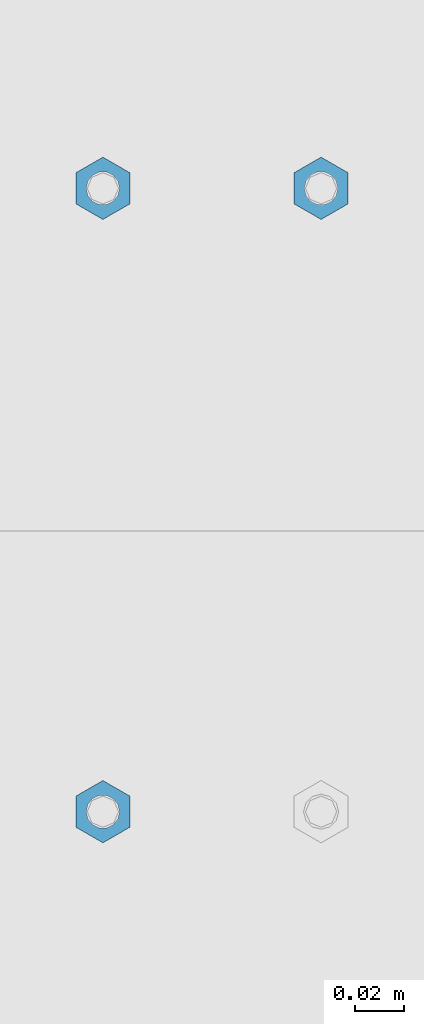
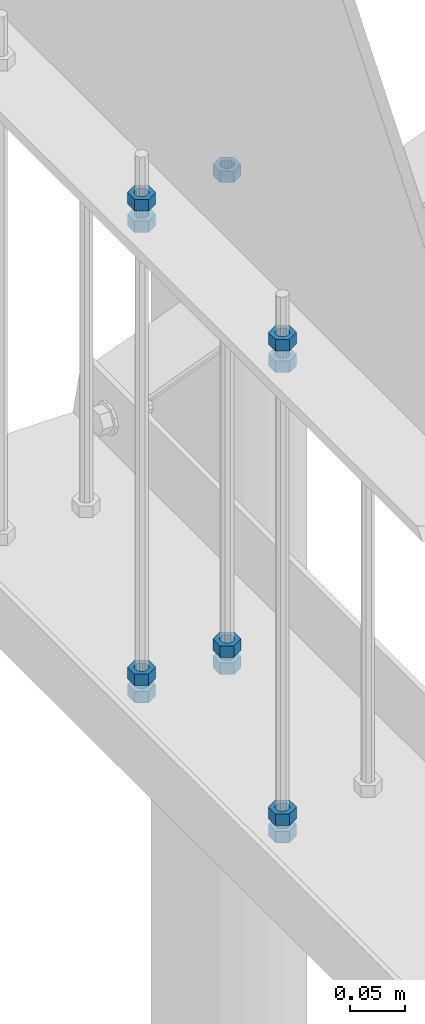
# One storey, part 299 of 975: 11 columns.
"""IFC2X3 building model written with IfcOpenShell, lengths in millimetres."""

from ifc_helpers import new_model, si_unit, frame, origin_with_axes, place, context, subcontext, project, spatial, faceted_brep, material, type_object, element, save


model = new_model("IFC2X3")

# Units and contexts
model_context = context("Model", 3, precision=1e-05, world=origin_with_axes())
body_context = subcontext(model_context, "Body", "Model", "MODEL_VIEW")
ifc_project = project(units=[si_unit("LENGTHUNIT", "METRE", prefix="MILLI"), si_unit("AREAUNIT", "SQUARE_METRE"), si_unit("VOLUMEUNIT", "CUBIC_METRE"), si_unit("MASSUNIT", "GRAM", prefix="KILO"), si_unit("TIMEUNIT", "SECOND"), si_unit("PLANEANGLEUNIT", "RADIAN"), si_unit("SOLIDANGLEUNIT", "STERADIAN"), si_unit("THERMODYNAMICTEMPERATUREUNIT", "DEGREE_CELSIUS"), si_unit("LUMINOUSINTENSITYUNIT", "LUMEN")], contexts=[model_context])

# Site, building, storey
site_placement = place(None, origin_with_axes())
site = spatial("IfcSite", under=ifc_project, at=site_placement, CompositionType="ELEMENT")
building_placement = place(site_placement, origin_with_axes())
building = spatial("IfcBuilding", under=site, at=building_placement, Name="Undefined", CompositionType="ELEMENT")
storey_placement = place(building_placement, origin_with_axes())
storey = spatial("IfcBuildingStorey", under=building, at=storey_placement, Name="Undefined", CompositionType="ELEMENT", Elevation=0.0)

# Columns
ifc_material = material(Name="STEEL/A307")
column_type = type_object("IfcColumnType", Name="1/2_HEAVY_HEX_NUT", PredefinedType="NOTDEFINED")
column_1_placement = place(storey_placement, frame((8274.05, 27771.725, 3424.2375), z_axis=(-0.999999999999998, 6.90000001668524e-08, 0.0), x_axis=(0.0, 0.0, 1.0)))
element("IfcColumn", 1, at=column_1_placement, inside=storey, type_object=column_type, material=ifc_material, Name="NUT", ObjectType="1/2_HEAVY_HEX_NUT", context=body_context, shape_type="Brep", body=[
    faceted_brep([(0.0, -12.6999998092506, -1.09139364212751e-11), (0.0, -6.34999990461802, -11.0000000000218), (12.6999999999998, -6.34999990461802, -11.0000000000218), (12.6999999999998, -12.6999998092506, -1.09139364212751e-11), (0.0, 6.34999990463257, -11.0000000000109), (12.6999999999998, 6.34999990463257, -11.0000000000109), (0.0, 12.6999998092506, 1.09139364212751e-11), (12.6999999999998, 12.6999998092506, 1.09139364212751e-11), (0.0, 6.34999990461802, 11.0000000000218), (12.6999999999998, 6.34999990461802, 11.0000000000218), (0.0, -6.34999990463984, 11.0000000000109), (12.6999999999998, -6.34999990463984, 11.0000000000109), (0.0, -7.27595761418343e-12, 6.75000000000728), (0.0, 2.92871523903523, 6.08153985835088), (12.6999999999998, 2.92871523903523, 6.08153985835088), (12.6999999999998, -7.27595761418343e-12, 6.75000000000728), (0.0, 5.27736250664748, 4.20855616255722), (12.6999999999998, 5.27736250664748, 4.20855616255722), (0.0, 6.58076340721527, 1.50201630420997), (12.6999999999998, 6.58076340721527, 1.50201630420997), (0.0, 6.58076340722255, -1.5020163042027), (12.6999999999998, 6.58076340722255, -1.5020163042027), (0.0, 5.27736250665839, -4.20855616254994), (12.6999999999998, 5.27736250665839, -4.20855616254994), (0.0, 2.92871523904614, -6.08153985834724), (12.6999999999998, 2.92871523904614, -6.08153985834724), (0.0, 3.63797880709171e-12, -6.75000000001273), (12.6999999999998, 3.63797880709171e-12, -6.75000000001273), (0.0, -2.92871523903523, -6.08153985835452), (12.6999999999998, -2.92871523903523, -6.08153985835452), (0.0, -5.27736250665475, -4.20855616255722), (12.6999999999998, -5.27736250665475, -4.20855616255722), (0.0, -6.58076340721891, -1.50201630421179), (12.6999999999998, -6.58076340721891, -1.50201630421179), (0.0, -6.58076340722255, 1.50201630419906), (12.6999999999998, -6.58076340722255, 1.50201630419906), (0.0, -5.27736250665839, 4.20855616254994), (12.6999999999998, -5.27736250665839, 4.20855616254994), (0.0, -2.92871523904614, 6.08153985834724), (12.6999999999998, -2.92871523904614, 6.08153985834724)], [[[0, 1, 2, 3]], [[1, 4, 5, 2]], [[4, 6, 7, 5]], [[6, 8, 9, 7]], [[8, 10, 11, 9]], [[10, 0, 3, 11]], [[12, 13, 14, 15]], [[13, 16, 17, 14]], [[16, 18, 19, 17]], [[18, 20, 21, 19]], [[20, 22, 23, 21]], [[22, 24, 25, 23]], [[24, 26, 27, 25]], [[26, 28, 29, 27]], [[28, 30, 31, 29]], [[30, 32, 33, 31]], [[32, 34, 35, 33]], [[34, 36, 37, 35]], [[36, 38, 39, 37]], [[38, 12, 15, 39]], [[5, 7, 9, 11, 3, 2], [17, 19, 21, 23, 25, 27, 29, 31, 33, 35, 37, 39, 15, 14]], [[10, 8, 6, 4, 1, 0], [38, 36, 34, 32, 30, 28, 26, 24, 22, 20, 18, 16, 13, 12]]]),
])
column_2_placement = place(storey_placement, frame((8274.05, 27771.725, 2901.95), z_axis=(-0.999999999999998, 6.90000001668524e-08, 0.0), x_axis=(0.0, 0.0, 1.0)))
element("IfcColumn", 2, at=column_2_placement, inside=storey, type_object=column_type, material=ifc_material, Name="NUT", ObjectType="1/2_HEAVY_HEX_NUT", context=body_context, shape_type="Brep", body=[
    faceted_brep([(0.0, -12.6999998092506, -1.09139364212751e-11), (0.0, -6.34999990461802, -11.0000000000218), (12.6999999999998, -6.34999990461802, -11.0000000000218), (12.6999999999998, -12.6999998092506, -1.09139364212751e-11), (0.0, 6.34999990463257, -11.0000000000109), (12.6999999999998, 6.34999990463257, -11.0000000000109), (0.0, 12.6999998092506, 1.09139364212751e-11), (12.6999999999998, 12.6999998092506, 1.09139364212751e-11), (0.0, 6.34999990461802, 11.0000000000218), (12.6999999999998, 6.34999990461802, 11.0000000000218), (0.0, -6.34999990463984, 11.0000000000109), (12.6999999999998, -6.34999990463984, 11.0000000000109), (0.0, -7.27595761418343e-12, 6.75000000000728), (0.0, 2.92871523903523, 6.08153985835088), (12.6999999999998, 2.92871523903523, 6.08153985835088), (12.6999999999998, -7.27595761418343e-12, 6.75000000000728), (0.0, 5.27736250664748, 4.20855616255722), (12.6999999999998, 5.27736250664748, 4.20855616255722), (0.0, 6.58076340721527, 1.50201630420997), (12.6999999999998, 6.58076340721527, 1.50201630420997), (0.0, 6.58076340722255, -1.5020163042027), (12.6999999999998, 6.58076340722255, -1.5020163042027), (0.0, 5.27736250665839, -4.20855616254994), (12.6999999999998, 5.27736250665839, -4.20855616254994), (0.0, 2.92871523904614, -6.08153985834724), (12.6999999999998, 2.92871523904614, -6.08153985834724), (0.0, 3.63797880709171e-12, -6.75000000001273), (12.6999999999998, 3.63797880709171e-12, -6.75000000001273), (0.0, -2.92871523903523, -6.08153985835452), (12.6999999999998, -2.92871523903523, -6.08153985835452), (0.0, -5.27736250665475, -4.20855616255722), (12.6999999999998, -5.27736250665475, -4.20855616255722), (0.0, -6.58076340721891, -1.50201630421179), (12.6999999999998, -6.58076340721891, -1.50201630421179), (0.0, -6.58076340722255, 1.50201630419906), (12.6999999999998, -6.58076340722255, 1.50201630419906), (0.0, -5.27736250665839, 4.20855616254994), (12.6999999999998, -5.27736250665839, 4.20855616254994), (0.0, -2.92871523904614, 6.08153985834724), (12.6999999999998, -2.92871523904614, 6.08153985834724)], [[[0, 1, 2, 3]], [[1, 4, 5, 2]], [[4, 6, 7, 5]], [[6, 8, 9, 7]], [[8, 10, 11, 9]], [[10, 0, 3, 11]], [[12, 13, 14, 15]], [[13, 16, 17, 14]], [[16, 18, 19, 17]], [[18, 20, 21, 19]], [[20, 22, 23, 21]], [[22, 24, 25, 23]], [[24, 26, 27, 25]], [[26, 28, 29, 27]], [[28, 30, 31, 29]], [[30, 32, 33, 31]], [[32, 34, 35, 33]], [[34, 36, 37, 35]], [[36, 38, 39, 37]], [[38, 12, 15, 39]], [[5, 7, 9, 11, 3, 2], [17, 19, 21, 23, 25, 27, 29, 31, 33, 35, 37, 39, 15, 14]], [[10, 8, 6, 4, 1, 0], [38, 36, 34, 32, 30, 28, 26, 24, 22, 20, 18, 16, 13, 12]]]),
])
column_3_placement = place(storey_placement, frame((8274.05, 27771.725, 2882.9), z_axis=(-0.999999999999998, 6.90000001668524e-08, 0.0), x_axis=(0.0, 0.0, 1.0)))
element("IfcColumn", 3, at=column_3_placement, inside=storey, type_object=column_type, material=ifc_material, Name="NUT", ObjectType="1/2_HEAVY_HEX_NUT", context=body_context, shape_type="Brep", body=[
    faceted_brep([(0.0, -12.6999998092506, -1.09139364212751e-11), (0.0, -6.34999990461802, -11.0000000000218), (12.6999999999998, -6.34999990461802, -11.0000000000218), (12.6999999999998, -12.6999998092506, -1.09139364212751e-11), (0.0, 6.34999990463257, -11.0000000000109), (12.6999999999998, 6.34999990463257, -11.0000000000109), (0.0, 12.6999998092506, 1.09139364212751e-11), (12.6999999999998, 12.6999998092506, 1.09139364212751e-11), (0.0, 6.34999990461802, 11.0000000000218), (12.6999999999998, 6.34999990461802, 11.0000000000218), (0.0, -6.34999990463984, 11.0000000000109), (12.6999999999998, -6.34999990463984, 11.0000000000109), (0.0, -7.27595761418343e-12, 6.75000000000728), (0.0, 2.92871523903523, 6.08153985835088), (12.6999999999998, 2.92871523903523, 6.08153985835088), (12.6999999999998, -7.27595761418343e-12, 6.75000000000728), (0.0, 5.27736250664748, 4.20855616255722), (12.6999999999998, 5.27736250664748, 4.20855616255722), (0.0, 6.58076340721527, 1.50201630420997), (12.6999999999998, 6.58076340721527, 1.50201630420997), (0.0, 6.58076340722255, -1.5020163042027), (12.6999999999998, 6.58076340722255, -1.5020163042027), (0.0, 5.27736250665839, -4.20855616254994), (12.6999999999998, 5.27736250665839, -4.20855616254994), (0.0, 2.92871523904614, -6.08153985834724), (12.6999999999998, 2.92871523904614, -6.08153985834724), (0.0, 3.63797880709171e-12, -6.75000000001273), (12.6999999999998, 3.63797880709171e-12, -6.75000000001273), (0.0, -2.92871523903523, -6.08153985835452), (12.6999999999998, -2.92871523903523, -6.08153985835452), (0.0, -5.27736250665475, -4.20855616255722), (12.6999999999998, -5.27736250665475, -4.20855616255722), (0.0, -6.58076340721891, -1.50201630421179), (12.6999999999998, -6.58076340721891, -1.50201630421179), (0.0, -6.58076340722255, 1.50201630419906), (12.6999999999998, -6.58076340722255, 1.50201630419906), (0.0, -5.27736250665839, 4.20855616254994), (12.6999999999998, -5.27736250665839, 4.20855616254994), (0.0, -2.92871523904614, 6.08153985834724), (12.6999999999998, -2.92871523904614, 6.08153985834724)], [[[0, 1, 2, 3]], [[1, 4, 5, 2]], [[4, 6, 7, 5]], [[6, 8, 9, 7]], [[8, 10, 11, 9]], [[10, 0, 3, 11]], [[12, 13, 14, 15]], [[13, 16, 17, 14]], [[16, 18, 19, 17]], [[18, 20, 21, 19]], [[20, 22, 23, 21]], [[22, 24, 25, 23]], [[24, 26, 27, 25]], [[26, 28, 29, 27]], [[28, 30, 31, 29]], [[30, 32, 33, 31]], [[32, 34, 35, 33]], [[34, 36, 37, 35]], [[36, 38, 39, 37]], [[38, 12, 15, 39]], [[5, 7, 9, 11, 3, 2], [17, 19, 21, 23, 25, 27, 29, 31, 33, 35, 37, 39, 15, 14]], [[10, 8, 6, 4, 1, 0], [38, 36, 34, 32, 30, 28, 26, 24, 22, 20, 18, 16, 13, 12]]]),
])
column_4_placement = place(storey_placement, frame((8185.15, 27771.725, 3400.425), z_axis=(-0.999999999999998, 6.90000001668524e-08, 0.0), x_axis=(0.0, 0.0, 1.0)))
element("IfcColumn", 4, at=column_4_placement, inside=storey, type_object=column_type, material=ifc_material, Name="NUT", ObjectType="1/2_HEAVY_HEX_NUT", context=body_context, shape_type="Brep", body=[
    faceted_brep([(0.0, -12.6999998092506, -1.09139364212751e-11), (0.0, -6.34999990461802, -11.0000000000218), (12.6999999999998, -6.34999990461802, -11.0000000000218), (12.6999999999998, -12.6999998092506, -1.09139364212751e-11), (0.0, 6.34999990463257, -11.0000000000109), (12.6999999999998, 6.34999990463257, -11.0000000000109), (0.0, 12.6999998092506, 1.09139364212751e-11), (12.6999999999998, 12.6999998092506, 1.09139364212751e-11), (0.0, 6.34999990461802, 11.0000000000218), (12.6999999999998, 6.34999990461802, 11.0000000000218), (0.0, -6.34999990463984, 11.0000000000109), (12.6999999999998, -6.34999990463984, 11.0000000000109), (0.0, -7.27595761418343e-12, 6.75000000000728), (0.0, 2.92871523903523, 6.08153985835088), (12.6999999999998, 2.92871523903523, 6.08153985835088), (12.6999999999998, -7.27595761418343e-12, 6.75000000000728), (0.0, 5.27736250664748, 4.20855616255722), (12.6999999999998, 5.27736250664748, 4.20855616255722), (0.0, 6.58076340721527, 1.50201630420997), (12.6999999999998, 6.58076340721527, 1.50201630420997), (0.0, 6.58076340722255, -1.5020163042027), (12.6999999999998, 6.58076340722255, -1.5020163042027), (0.0, 5.27736250665839, -4.20855616254994), (12.6999999999998, 5.27736250665839, -4.20855616254994), (0.0, 2.92871523904614, -6.08153985834724), (12.6999999999998, 2.92871523904614, -6.08153985834724), (0.0, 3.63797880709171e-12, -6.75000000001273), (12.6999999999998, 3.63797880709171e-12, -6.75000000001273), (0.0, -2.92871523903523, -6.08153985835452), (12.6999999999998, -2.92871523903523, -6.08153985835452), (0.0, -5.27736250665475, -4.20855616255722), (12.6999999999998, -5.27736250665475, -4.20855616255722), (0.0, -6.58076340721891, -1.50201630421179), (12.6999999999998, -6.58076340721891, -1.50201630421179), (0.0, -6.58076340722255, 1.50201630419906), (12.6999999999998, -6.58076340722255, 1.50201630419906), (0.0, -5.27736250665839, 4.20855616254994), (12.6999999999998, -5.27736250665839, 4.20855616254994), (0.0, -2.92871523904614, 6.08153985834724), (12.6999999999998, -2.92871523904614, 6.08153985834724)], [[[0, 1, 2, 3]], [[1, 4, 5, 2]], [[4, 6, 7, 5]], [[6, 8, 9, 7]], [[8, 10, 11, 9]], [[10, 0, 3, 11]], [[12, 13, 14, 15]], [[13, 16, 17, 14]], [[16, 18, 19, 17]], [[18, 20, 21, 19]], [[20, 22, 23, 21]], [[22, 24, 25, 23]], [[24, 26, 27, 25]], [[26, 28, 29, 27]], [[28, 30, 31, 29]], [[30, 32, 33, 31]], [[32, 34, 35, 33]], [[34, 36, 37, 35]], [[36, 38, 39, 37]], [[38, 12, 15, 39]], [[5, 7, 9, 11, 3, 2], [17, 19, 21, 23, 25, 27, 29, 31, 33, 35, 37, 39, 15, 14]], [[10, 8, 6, 4, 1, 0], [38, 36, 34, 32, 30, 28, 26, 24, 22, 20, 18, 16, 13, 12]]]),
])
column_5_placement = place(storey_placement, frame((8185.15, 27771.725, 3424.2375), z_axis=(-0.999999999999998, 6.90000001668524e-08, 0.0), x_axis=(0.0, 0.0, 1.0)))
element("IfcColumn", 5, at=column_5_placement, inside=storey, type_object=column_type, material=ifc_material, Name="NUT", ObjectType="1/2_HEAVY_HEX_NUT", context=body_context, shape_type="Brep", body=[
    faceted_brep([(0.0, -12.6999998092506, -1.09139364212751e-11), (0.0, -6.34999990461802, -11.0000000000218), (12.6999999999998, -6.34999990461802, -11.0000000000218), (12.6999999999998, -12.6999998092506, -1.09139364212751e-11), (0.0, 6.34999990463257, -11.0000000000109), (12.6999999999998, 6.34999990463257, -11.0000000000109), (0.0, 12.6999998092506, 1.09139364212751e-11), (12.6999999999998, 12.6999998092506, 1.09139364212751e-11), (0.0, 6.34999990461802, 11.0000000000218), (12.6999999999998, 6.34999990461802, 11.0000000000218), (0.0, -6.34999990463984, 11.0000000000109), (12.6999999999998, -6.34999990463984, 11.0000000000109), (0.0, -7.27595761418343e-12, 6.75000000000728), (0.0, 2.92871523903523, 6.08153985835088), (12.6999999999998, 2.92871523903523, 6.08153985835088), (12.6999999999998, -7.27595761418343e-12, 6.75000000000728), (0.0, 5.27736250664748, 4.20855616255722), (12.6999999999998, 5.27736250664748, 4.20855616255722), (0.0, 6.58076340721527, 1.50201630420997), (12.6999999999998, 6.58076340721527, 1.50201630420997), (0.0, 6.58076340722255, -1.5020163042027), (12.6999999999998, 6.58076340722255, -1.5020163042027), (0.0, 5.27736250665839, -4.20855616254994), (12.6999999999998, 5.27736250665839, -4.20855616254994), (0.0, 2.92871523904614, -6.08153985834724), (12.6999999999998, 2.92871523904614, -6.08153985834724), (0.0, 3.63797880709171e-12, -6.75000000001273), (12.6999999999998, 3.63797880709171e-12, -6.75000000001273), (0.0, -2.92871523903523, -6.08153985835452), (12.6999999999998, -2.92871523903523, -6.08153985835452), (0.0, -5.27736250665475, -4.20855616255722), (12.6999999999998, -5.27736250665475, -4.20855616255722), (0.0, -6.58076340721891, -1.50201630421179), (12.6999999999998, -6.58076340721891, -1.50201630421179), (0.0, -6.58076340722255, 1.50201630419906), (12.6999999999998, -6.58076340722255, 1.50201630419906), (0.0, -5.27736250665839, 4.20855616254994), (12.6999999999998, -5.27736250665839, 4.20855616254994), (0.0, -2.92871523904614, 6.08153985834724), (12.6999999999998, -2.92871523904614, 6.08153985834724)], [[[0, 1, 2, 3]], [[1, 4, 5, 2]], [[4, 6, 7, 5]], [[6, 8, 9, 7]], [[8, 10, 11, 9]], [[10, 0, 3, 11]], [[12, 13, 14, 15]], [[13, 16, 17, 14]], [[16, 18, 19, 17]], [[18, 20, 21, 19]], [[20, 22, 23, 21]], [[22, 24, 25, 23]], [[24, 26, 27, 25]], [[26, 28, 29, 27]], [[28, 30, 31, 29]], [[30, 32, 33, 31]], [[32, 34, 35, 33]], [[34, 36, 37, 35]], [[36, 38, 39, 37]], [[38, 12, 15, 39]], [[5, 7, 9, 11, 3, 2], [17, 19, 21, 23, 25, 27, 29, 31, 33, 35, 37, 39, 15, 14]], [[10, 8, 6, 4, 1, 0], [38, 36, 34, 32, 30, 28, 26, 24, 22, 20, 18, 16, 13, 12]]]),
])
column_6_placement = place(storey_placement, frame((8185.15, 27771.725, 2901.95), z_axis=(-0.999999999999998, 6.90000001668524e-08, 0.0), x_axis=(0.0, 0.0, 1.0)))
element("IfcColumn", 6, at=column_6_placement, inside=storey, type_object=column_type, material=ifc_material, Name="NUT", ObjectType="1/2_HEAVY_HEX_NUT", context=body_context, shape_type="Brep", body=[
    faceted_brep([(0.0, -12.6999998092506, -1.09139364212751e-11), (0.0, -6.34999990461802, -11.0000000000218), (12.6999999999998, -6.34999990461802, -11.0000000000218), (12.6999999999998, -12.6999998092506, -1.09139364212751e-11), (0.0, 6.34999990463257, -11.0000000000109), (12.6999999999998, 6.34999990463257, -11.0000000000109), (0.0, 12.6999998092506, 1.09139364212751e-11), (12.6999999999998, 12.6999998092506, 1.09139364212751e-11), (0.0, 6.34999990461802, 11.0000000000218), (12.6999999999998, 6.34999990461802, 11.0000000000218), (0.0, -6.34999990463984, 11.0000000000109), (12.6999999999998, -6.34999990463984, 11.0000000000109), (0.0, -7.27595761418343e-12, 6.75000000000728), (0.0, 2.92871523903523, 6.08153985835088), (12.6999999999998, 2.92871523903523, 6.08153985835088), (12.6999999999998, -7.27595761418343e-12, 6.75000000000728), (0.0, 5.27736250664748, 4.20855616255722), (12.6999999999998, 5.27736250664748, 4.20855616255722), (0.0, 6.58076340721527, 1.50201630420997), (12.6999999999998, 6.58076340721527, 1.50201630420997), (0.0, 6.58076340722255, -1.5020163042027), (12.6999999999998, 6.58076340722255, -1.5020163042027), (0.0, 5.27736250665839, -4.20855616254994), (12.6999999999998, 5.27736250665839, -4.20855616254994), (0.0, 2.92871523904614, -6.08153985834724), (12.6999999999998, 2.92871523904614, -6.08153985834724), (0.0, 3.63797880709171e-12, -6.75000000001273), (12.6999999999998, 3.63797880709171e-12, -6.75000000001273), (0.0, -2.92871523903523, -6.08153985835452), (12.6999999999998, -2.92871523903523, -6.08153985835452), (0.0, -5.27736250665475, -4.20855616255722), (12.6999999999998, -5.27736250665475, -4.20855616255722), (0.0, -6.58076340721891, -1.50201630421179), (12.6999999999998, -6.58076340721891, -1.50201630421179), (0.0, -6.58076340722255, 1.50201630419906), (12.6999999999998, -6.58076340722255, 1.50201630419906), (0.0, -5.27736250665839, 4.20855616254994), (12.6999999999998, -5.27736250665839, 4.20855616254994), (0.0, -2.92871523904614, 6.08153985834724), (12.6999999999998, -2.92871523904614, 6.08153985834724)], [[[0, 1, 2, 3]], [[1, 4, 5, 2]], [[4, 6, 7, 5]], [[6, 8, 9, 7]], [[8, 10, 11, 9]], [[10, 0, 3, 11]], [[12, 13, 14, 15]], [[13, 16, 17, 14]], [[16, 18, 19, 17]], [[18, 20, 21, 19]], [[20, 22, 23, 21]], [[22, 24, 25, 23]], [[24, 26, 27, 25]], [[26, 28, 29, 27]], [[28, 30, 31, 29]], [[30, 32, 33, 31]], [[32, 34, 35, 33]], [[34, 36, 37, 35]], [[36, 38, 39, 37]], [[38, 12, 15, 39]], [[5, 7, 9, 11, 3, 2], [17, 19, 21, 23, 25, 27, 29, 31, 33, 35, 37, 39, 15, 14]], [[10, 8, 6, 4, 1, 0], [38, 36, 34, 32, 30, 28, 26, 24, 22, 20, 18, 16, 13, 12]]]),
])
column_7_placement = place(storey_placement, frame((8185.15, 27771.725, 2882.9), z_axis=(-0.999999999999998, 6.90000001668524e-08, 0.0), x_axis=(0.0, 0.0, 1.0)))
element("IfcColumn", 7, at=column_7_placement, inside=storey, type_object=column_type, material=ifc_material, Name="NUT", ObjectType="1/2_HEAVY_HEX_NUT", context=body_context, shape_type="Brep", body=[
    faceted_brep([(0.0, -12.6999998092506, -1.09139364212751e-11), (0.0, -6.34999990461802, -11.0000000000218), (12.6999999999998, -6.34999990461802, -11.0000000000218), (12.6999999999998, -12.6999998092506, -1.09139364212751e-11), (0.0, 6.34999990463257, -11.0000000000109), (12.6999999999998, 6.34999990463257, -11.0000000000109), (0.0, 12.6999998092506, 1.09139364212751e-11), (12.6999999999998, 12.6999998092506, 1.09139364212751e-11), (0.0, 6.34999990461802, 11.0000000000218), (12.6999999999998, 6.34999990461802, 11.0000000000218), (0.0, -6.34999990463984, 11.0000000000109), (12.6999999999998, -6.34999990463984, 11.0000000000109), (0.0, -7.27595761418343e-12, 6.75000000000728), (0.0, 2.92871523903523, 6.08153985835088), (12.6999999999998, 2.92871523903523, 6.08153985835088), (12.6999999999998, -7.27595761418343e-12, 6.75000000000728), (0.0, 5.27736250664748, 4.20855616255722), (12.6999999999998, 5.27736250664748, 4.20855616255722), (0.0, 6.58076340721527, 1.50201630420997), (12.6999999999998, 6.58076340721527, 1.50201630420997), (0.0, 6.58076340722255, -1.5020163042027), (12.6999999999998, 6.58076340722255, -1.5020163042027), (0.0, 5.27736250665839, -4.20855616254994), (12.6999999999998, 5.27736250665839, -4.20855616254994), (0.0, 2.92871523904614, -6.08153985834724), (12.6999999999998, 2.92871523904614, -6.08153985834724), (0.0, 3.63797880709171e-12, -6.75000000001273), (12.6999999999998, 3.63797880709171e-12, -6.75000000001273), (0.0, -2.92871523903523, -6.08153985835452), (12.6999999999998, -2.92871523903523, -6.08153985835452), (0.0, -5.27736250665475, -4.20855616255722), (12.6999999999998, -5.27736250665475, -4.20855616255722), (0.0, -6.58076340721891, -1.50201630421179), (12.6999999999998, -6.58076340721891, -1.50201630421179), (0.0, -6.58076340722255, 1.50201630419906), (12.6999999999998, -6.58076340722255, 1.50201630419906), (0.0, -5.27736250665839, 4.20855616254994), (12.6999999999998, -5.27736250665839, 4.20855616254994), (0.0, -2.92871523904614, 6.08153985834724), (12.6999999999998, -2.92871523904614, 6.08153985834724)], [[[0, 1, 2, 3]], [[1, 4, 5, 2]], [[4, 6, 7, 5]], [[6, 8, 9, 7]], [[8, 10, 11, 9]], [[10, 0, 3, 11]], [[12, 13, 14, 15]], [[13, 16, 17, 14]], [[16, 18, 19, 17]], [[18, 20, 21, 19]], [[20, 22, 23, 21]], [[22, 24, 25, 23]], [[24, 26, 27, 25]], [[26, 28, 29, 27]], [[28, 30, 31, 29]], [[30, 32, 33, 31]], [[32, 34, 35, 33]], [[34, 36, 37, 35]], [[36, 38, 39, 37]], [[38, 12, 15, 39]], [[5, 7, 9, 11, 3, 2], [17, 19, 21, 23, 25, 27, 29, 31, 33, 35, 37, 39, 15, 14]], [[10, 8, 6, 4, 1, 0], [38, 36, 34, 32, 30, 28, 26, 24, 22, 20, 18, 16, 13, 12]]]),
])
column_8_placement = place(storey_placement, frame((8185.15, 27517.725, 3400.425), z_axis=(-0.999999999999998, 6.90000001668524e-08, 0.0), x_axis=(0.0, 0.0, 1.0)))
element("IfcColumn", 8, at=column_8_placement, inside=storey, type_object=column_type, material=ifc_material, Name="NUT", ObjectType="1/2_HEAVY_HEX_NUT", context=body_context, shape_type="Brep", body=[
    faceted_brep([(0.0, -12.6999998092506, -1.09139364212751e-11), (0.0, -6.34999990461802, -11.0000000000218), (12.6999999999998, -6.34999990461802, -11.0000000000218), (12.6999999999998, -12.6999998092506, -1.09139364212751e-11), (0.0, 6.34999990463257, -11.0000000000109), (12.6999999999998, 6.34999990463257, -11.0000000000109), (0.0, 12.6999998092506, 1.09139364212751e-11), (12.6999999999998, 12.6999998092506, 1.09139364212751e-11), (0.0, 6.34999990461802, 11.0000000000218), (12.6999999999998, 6.34999990461802, 11.0000000000218), (0.0, -6.34999990463984, 11.0000000000109), (12.6999999999998, -6.34999990463984, 11.0000000000109), (0.0, -7.27595761418343e-12, 6.75000000000728), (0.0, 2.92871523903523, 6.08153985835088), (12.6999999999998, 2.92871523903523, 6.08153985835088), (12.6999999999998, -7.27595761418343e-12, 6.75000000000728), (0.0, 5.27736250664748, 4.20855616255722), (12.6999999999998, 5.27736250664748, 4.20855616255722), (0.0, 6.58076340721527, 1.50201630420997), (12.6999999999998, 6.58076340721527, 1.50201630420997), (0.0, 6.58076340722255, -1.5020163042027), (12.6999999999998, 6.58076340722255, -1.5020163042027), (0.0, 5.27736250665839, -4.20855616254994), (12.6999999999998, 5.27736250665839, -4.20855616254994), (0.0, 2.92871523904614, -6.08153985834724), (12.6999999999998, 2.92871523904614, -6.08153985834724), (0.0, 3.63797880709171e-12, -6.75000000001273), (12.6999999999998, 3.63797880709171e-12, -6.75000000001273), (0.0, -2.92871523903523, -6.08153985835452), (12.6999999999998, -2.92871523903523, -6.08153985835452), (0.0, -5.27736250665475, -4.20855616255722), (12.6999999999998, -5.27736250665475, -4.20855616255722), (0.0, -6.58076340721891, -1.50201630421179), (12.6999999999998, -6.58076340721891, -1.50201630421179), (0.0, -6.58076340722255, 1.50201630419906), (12.6999999999998, -6.58076340722255, 1.50201630419906), (0.0, -5.27736250665839, 4.20855616254994), (12.6999999999998, -5.27736250665839, 4.20855616254994), (0.0, -2.92871523904614, 6.08153985834724), (12.6999999999998, -2.92871523904614, 6.08153985834724)], [[[0, 1, 2, 3]], [[1, 4, 5, 2]], [[4, 6, 7, 5]], [[6, 8, 9, 7]], [[8, 10, 11, 9]], [[10, 0, 3, 11]], [[12, 13, 14, 15]], [[13, 16, 17, 14]], [[16, 18, 19, 17]], [[18, 20, 21, 19]], [[20, 22, 23, 21]], [[22, 24, 25, 23]], [[24, 26, 27, 25]], [[26, 28, 29, 27]], [[28, 30, 31, 29]], [[30, 32, 33, 31]], [[32, 34, 35, 33]], [[34, 36, 37, 35]], [[36, 38, 39, 37]], [[38, 12, 15, 39]], [[5, 7, 9, 11, 3, 2], [17, 19, 21, 23, 25, 27, 29, 31, 33, 35, 37, 39, 15, 14]], [[10, 8, 6, 4, 1, 0], [38, 36, 34, 32, 30, 28, 26, 24, 22, 20, 18, 16, 13, 12]]]),
])
column_9_placement = place(storey_placement, frame((8185.15, 27517.725, 3424.2375), z_axis=(-0.999999999999998, 6.90000001668524e-08, 0.0), x_axis=(0.0, 0.0, 1.0)))
element("IfcColumn", 9, at=column_9_placement, inside=storey, type_object=column_type, material=ifc_material, Name="NUT", ObjectType="1/2_HEAVY_HEX_NUT", context=body_context, shape_type="Brep", body=[
    faceted_brep([(0.0, -12.6999998092506, -1.09139364212751e-11), (0.0, -6.34999990461802, -11.0000000000218), (12.6999999999998, -6.34999990461802, -11.0000000000218), (12.6999999999998, -12.6999998092506, -1.09139364212751e-11), (0.0, 6.34999990463257, -11.0000000000109), (12.6999999999998, 6.34999990463257, -11.0000000000109), (0.0, 12.6999998092506, 1.09139364212751e-11), (12.6999999999998, 12.6999998092506, 1.09139364212751e-11), (0.0, 6.34999990461802, 11.0000000000218), (12.6999999999998, 6.34999990461802, 11.0000000000218), (0.0, -6.34999990463984, 11.0000000000109), (12.6999999999998, -6.34999990463984, 11.0000000000109), (0.0, -7.27595761418343e-12, 6.75000000000728), (0.0, 2.92871523903523, 6.08153985835088), (12.6999999999998, 2.92871523903523, 6.08153985835088), (12.6999999999998, -7.27595761418343e-12, 6.75000000000728), (0.0, 5.27736250664748, 4.20855616255722), (12.6999999999998, 5.27736250664748, 4.20855616255722), (0.0, 6.58076340721527, 1.50201630420997), (12.6999999999998, 6.58076340721527, 1.50201630420997), (0.0, 6.58076340722255, -1.5020163042027), (12.6999999999998, 6.58076340722255, -1.5020163042027), (0.0, 5.27736250665839, -4.20855616254994), (12.6999999999998, 5.27736250665839, -4.20855616254994), (0.0, 2.92871523904614, -6.08153985834724), (12.6999999999998, 2.92871523904614, -6.08153985834724), (0.0, 3.63797880709171e-12, -6.75000000001273), (12.6999999999998, 3.63797880709171e-12, -6.75000000001273), (0.0, -2.92871523903523, -6.08153985835452), (12.6999999999998, -2.92871523903523, -6.08153985835452), (0.0, -5.27736250665475, -4.20855616255722), (12.6999999999998, -5.27736250665475, -4.20855616255722), (0.0, -6.58076340721891, -1.50201630421179), (12.6999999999998, -6.58076340721891, -1.50201630421179), (0.0, -6.58076340722255, 1.50201630419906), (12.6999999999998, -6.58076340722255, 1.50201630419906), (0.0, -5.27736250665839, 4.20855616254994), (12.6999999999998, -5.27736250665839, 4.20855616254994), (0.0, -2.92871523904614, 6.08153985834724), (12.6999999999998, -2.92871523904614, 6.08153985834724)], [[[0, 1, 2, 3]], [[1, 4, 5, 2]], [[4, 6, 7, 5]], [[6, 8, 9, 7]], [[8, 10, 11, 9]], [[10, 0, 3, 11]], [[12, 13, 14, 15]], [[13, 16, 17, 14]], [[16, 18, 19, 17]], [[18, 20, 21, 19]], [[20, 22, 23, 21]], [[22, 24, 25, 23]], [[24, 26, 27, 25]], [[26, 28, 29, 27]], [[28, 30, 31, 29]], [[30, 32, 33, 31]], [[32, 34, 35, 33]], [[34, 36, 37, 35]], [[36, 38, 39, 37]], [[38, 12, 15, 39]], [[5, 7, 9, 11, 3, 2], [17, 19, 21, 23, 25, 27, 29, 31, 33, 35, 37, 39, 15, 14]], [[10, 8, 6, 4, 1, 0], [38, 36, 34, 32, 30, 28, 26, 24, 22, 20, 18, 16, 13, 12]]]),
])
column_10_placement = place(storey_placement, frame((8185.15, 27517.725, 2901.95), z_axis=(-0.999999999999998, 6.90000001668524e-08, 0.0), x_axis=(0.0, 0.0, 1.0)))
element("IfcColumn", 10, at=column_10_placement, inside=storey, type_object=column_type, material=ifc_material, Name="NUT", ObjectType="1/2_HEAVY_HEX_NUT", context=body_context, shape_type="Brep", body=[
    faceted_brep([(0.0, -12.6999998092506, -1.09139364212751e-11), (0.0, -6.34999990461802, -11.0000000000218), (12.6999999999998, -6.34999990461802, -11.0000000000218), (12.6999999999998, -12.6999998092506, -1.09139364212751e-11), (0.0, 6.34999990463257, -11.0000000000109), (12.6999999999998, 6.34999990463257, -11.0000000000109), (0.0, 12.6999998092506, 1.09139364212751e-11), (12.6999999999998, 12.6999998092506, 1.09139364212751e-11), (0.0, 6.34999990461802, 11.0000000000218), (12.6999999999998, 6.34999990461802, 11.0000000000218), (0.0, -6.34999990463984, 11.0000000000109), (12.6999999999998, -6.34999990463984, 11.0000000000109), (0.0, -7.27595761418343e-12, 6.75000000000728), (0.0, 2.92871523903523, 6.08153985835088), (12.6999999999998, 2.92871523903523, 6.08153985835088), (12.6999999999998, -7.27595761418343e-12, 6.75000000000728), (0.0, 5.27736250664748, 4.20855616255722), (12.6999999999998, 5.27736250664748, 4.20855616255722), (0.0, 6.58076340721527, 1.50201630420997), (12.6999999999998, 6.58076340721527, 1.50201630420997), (0.0, 6.58076340722255, -1.5020163042027), (12.6999999999998, 6.58076340722255, -1.5020163042027), (0.0, 5.27736250665839, -4.20855616254994), (12.6999999999998, 5.27736250665839, -4.20855616254994), (0.0, 2.92871523904614, -6.08153985834724), (12.6999999999998, 2.92871523904614, -6.08153985834724), (0.0, 3.63797880709171e-12, -6.75000000001273), (12.6999999999998, 3.63797880709171e-12, -6.75000000001273), (0.0, -2.92871523903523, -6.08153985835452), (12.6999999999998, -2.92871523903523, -6.08153985835452), (0.0, -5.27736250665475, -4.20855616255722), (12.6999999999998, -5.27736250665475, -4.20855616255722), (0.0, -6.58076340721891, -1.50201630421179), (12.6999999999998, -6.58076340721891, -1.50201630421179), (0.0, -6.58076340722255, 1.50201630419906), (12.6999999999998, -6.58076340722255, 1.50201630419906), (0.0, -5.27736250665839, 4.20855616254994), (12.6999999999998, -5.27736250665839, 4.20855616254994), (0.0, -2.92871523904614, 6.08153985834724), (12.6999999999998, -2.92871523904614, 6.08153985834724)], [[[0, 1, 2, 3]], [[1, 4, 5, 2]], [[4, 6, 7, 5]], [[6, 8, 9, 7]], [[8, 10, 11, 9]], [[10, 0, 3, 11]], [[12, 13, 14, 15]], [[13, 16, 17, 14]], [[16, 18, 19, 17]], [[18, 20, 21, 19]], [[20, 22, 23, 21]], [[22, 24, 25, 23]], [[24, 26, 27, 25]], [[26, 28, 29, 27]], [[28, 30, 31, 29]], [[30, 32, 33, 31]], [[32, 34, 35, 33]], [[34, 36, 37, 35]], [[36, 38, 39, 37]], [[38, 12, 15, 39]], [[5, 7, 9, 11, 3, 2], [17, 19, 21, 23, 25, 27, 29, 31, 33, 35, 37, 39, 15, 14]], [[10, 8, 6, 4, 1, 0], [38, 36, 34, 32, 30, 28, 26, 24, 22, 20, 18, 16, 13, 12]]]),
])
column_11_placement = place(storey_placement, frame((8185.15, 27517.725, 2882.9), z_axis=(-0.999999999999998, 6.90000001668524e-08, 0.0), x_axis=(0.0, 0.0, 1.0)))
element("IfcColumn", 11, at=column_11_placement, inside=storey, type_object=column_type, material=ifc_material, Name="NUT", ObjectType="1/2_HEAVY_HEX_NUT", context=body_context, shape_type="Brep", body=[
    faceted_brep([(0.0, -12.6999998092506, -1.09139364212751e-11), (0.0, -6.34999990461802, -11.0000000000218), (12.6999999999998, -6.34999990461802, -11.0000000000218), (12.6999999999998, -12.6999998092506, -1.09139364212751e-11), (0.0, 6.34999990463257, -11.0000000000109), (12.6999999999998, 6.34999990463257, -11.0000000000109), (0.0, 12.6999998092506, 1.09139364212751e-11), (12.6999999999998, 12.6999998092506, 1.09139364212751e-11), (0.0, 6.34999990461802, 11.0000000000218), (12.6999999999998, 6.34999990461802, 11.0000000000218), (0.0, -6.34999990463984, 11.0000000000109), (12.6999999999998, -6.34999990463984, 11.0000000000109), (0.0, -7.27595761418343e-12, 6.75000000000728), (0.0, 2.92871523903523, 6.08153985835088), (12.6999999999998, 2.92871523903523, 6.08153985835088), (12.6999999999998, -7.27595761418343e-12, 6.75000000000728), (0.0, 5.27736250664748, 4.20855616255722), (12.6999999999998, 5.27736250664748, 4.20855616255722), (0.0, 6.58076340721527, 1.50201630420997), (12.6999999999998, 6.58076340721527, 1.50201630420997), (0.0, 6.58076340722255, -1.5020163042027), (12.6999999999998, 6.58076340722255, -1.5020163042027), (0.0, 5.27736250665839, -4.20855616254994), (12.6999999999998, 5.27736250665839, -4.20855616254994), (0.0, 2.92871523904614, -6.08153985834724), (12.6999999999998, 2.92871523904614, -6.08153985834724), (0.0, 3.63797880709171e-12, -6.75000000001273), (12.6999999999998, 3.63797880709171e-12, -6.75000000001273), (0.0, -2.92871523903523, -6.08153985835452), (12.6999999999998, -2.92871523903523, -6.08153985835452), (0.0, -5.27736250665475, -4.20855616255722), (12.6999999999998, -5.27736250665475, -4.20855616255722), (0.0, -6.58076340721891, -1.50201630421179), (12.6999999999998, -6.58076340721891, -1.50201630421179), (0.0, -6.58076340722255, 1.50201630419906), (12.6999999999998, -6.58076340722255, 1.50201630419906), (0.0, -5.27736250665839, 4.20855616254994), (12.6999999999998, -5.27736250665839, 4.20855616254994), (0.0, -2.92871523904614, 6.08153985834724), (12.6999999999998, -2.92871523904614, 6.08153985834724)], [[[0, 1, 2, 3]], [[1, 4, 5, 2]], [[4, 6, 7, 5]], [[6, 8, 9, 7]], [[8, 10, 11, 9]], [[10, 0, 3, 11]], [[12, 13, 14, 15]], [[13, 16, 17, 14]], [[16, 18, 19, 17]], [[18, 20, 21, 19]], [[20, 22, 23, 21]], [[22, 24, 25, 23]], [[24, 26, 27, 25]], [[26, 28, 29, 27]], [[28, 30, 31, 29]], [[30, 32, 33, 31]], [[32, 34, 35, 33]], [[34, 36, 37, 35]], [[36, 38, 39, 37]], [[38, 12, 15, 39]], [[5, 7, 9, 11, 3, 2], [17, 19, 21, 23, 25, 27, 29, 31, 33, 35, 37, 39, 15, 14]], [[10, 8, 6, 4, 1, 0], [38, 36, 34, 32, 30, 28, 26, 24, 22, 20, 18, 16, 13, 12]]]),
])

save(model, "model.ifc")
